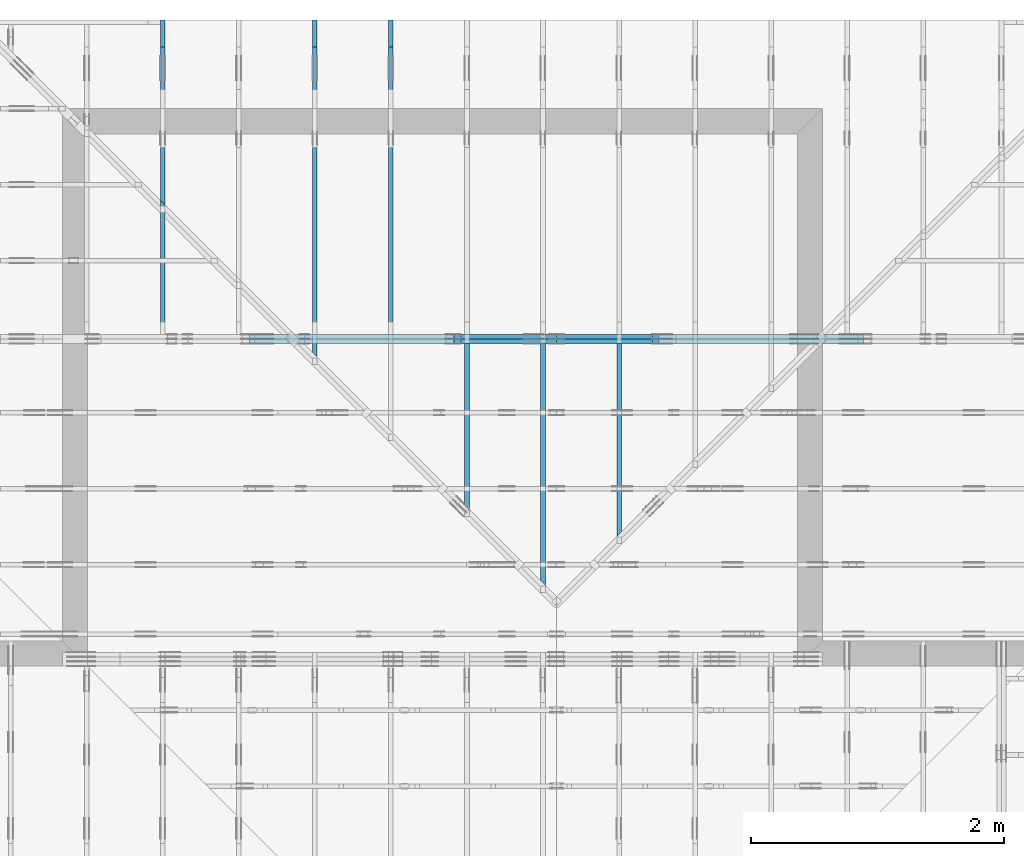
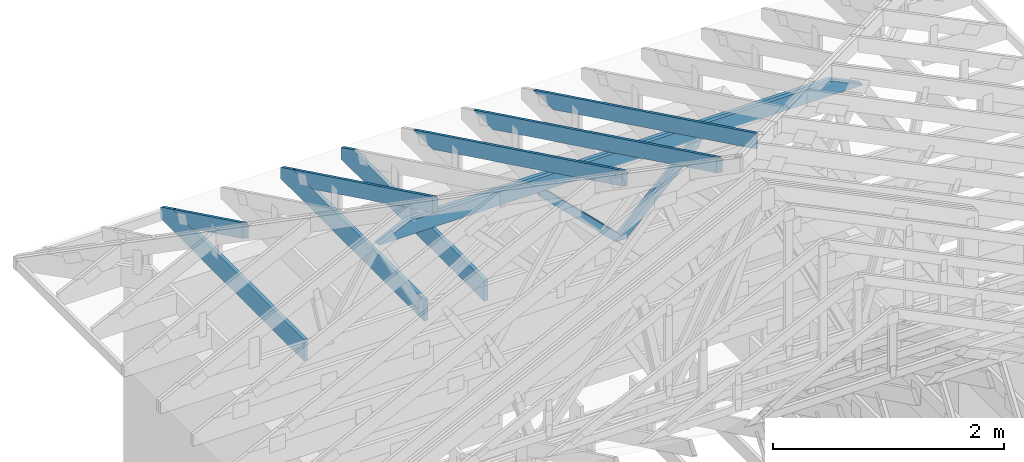
# One storey, part 27 of 159: 14 members, 7 elements without a shape of their own.
"""IFC2X3 building model written with IfcOpenShell, lengths in millimetres."""

import ifcopenshell
import ifcopenshell.guid

model = None  # the IFC model being written
_history = None  # IfcOwnerHistory: only IFC2X3 demands one
_inside = {}  # id of a spatial element -> (the spatial element, [elements in it])
_under = {}  # id of a project, library or spatial element -> (it, [spatial elements below it])
_declared = {}  # id of a project -> (the project, [libraries it declares])
_typed = {}  # id of a type object -> (the type object, [elements of that type])
_made_of = {}  # id of a material, layer set ... -> (it, [elements and type objects made of it])


def new_model(schema):
    """Start an empty IFC model of exactly this schema.

    Asked for "IFC4X3", IfcOpenShell would pick the latest addendum, in which some entities
    have other attributes; the version numbers below select the first issue.
    IFC2X3 requires an IfcOwnerHistory on every rooted entity: one is made here for all.
    """
    global model, _history
    if schema == "IFC4X3":
        model = ifcopenshell.file(schema_version=(4, 3, 0, 0))
    else:
        model = ifcopenshell.file(schema=schema)
    _inside.clear()
    _under.clear()
    _declared.clear()
    _typed.clear()
    _made_of.clear()
    _history = None
    if model.schema == "IFC2X3":
        org = make("IfcOrganization", Name="unknown")
        user = make(
            "IfcPersonAndOrganization",
            ThePerson=make("IfcPerson", FamilyName="unknown"),
            TheOrganization=org,
        )
        app = make(
            "IfcApplication",
            ApplicationDeveloper=org,
            Version="unknown",
            ApplicationFullName="unknown",
            ApplicationIdentifier="unknown",
        )
        _history = make(
            "IfcOwnerHistory",
            OwningUser=user,
            OwningApplication=app,
            ChangeAction="ADDED",
            CreationDate=0,
        )
    return model


def make(cls, **values):
    """One entity of the class cls with the attributes given. An attribute that is None is left unset."""
    return model.create_entity(
        cls, **{name: value for name, value in values.items() if value is not None}
    )


def rooted(cls, **values):
    """An entity with a GlobalId (a new one), such as an element, a storey or a relation."""
    return make(cls, GlobalId=ifcopenshell.guid.new(), OwnerHistory=_history, **values)


def si_unit(unit_type, name, prefix=None):
    """IfcSIUnit, for example si_unit("LENGTHUNIT", "METRE", prefix="MILLI")."""
    return make("IfcSIUnit", UnitType=unit_type, Prefix=prefix, Name=name)


def assignment(units):
    """IfcUnitAssignment: the units of a project."""
    return None if units is None else make("IfcUnitAssignment", Units=units)


def point(xyz):
    """IfcCartesianPoint."""
    return None if xyz is None else make("IfcCartesianPoint", Coordinates=xyz)


def direction(xyz):
    """IfcDirection."""
    return None if xyz is None else make("IfcDirection", DirectionRatios=xyz)


def frame(location, z_axis=None, x_axis=None):
    """IfcAxis2Placement3D, a coordinate frame: its origin and axes. An axis left out is left unset."""
    return make(
        "IfcAxis2Placement3D",
        Location=point(location),
        Axis=direction(z_axis),
        RefDirection=direction(x_axis),
    )


def frame_2d(location, x_axis=None):
    """IfcAxis2Placement2D, a coordinate frame in the plane: its origin and x axis."""
    return make(
        "IfcAxis2Placement2D", Location=point(location), RefDirection=direction(x_axis)
    )


def origin():
    """The frame at (0, 0, 0) with its axes left unset."""
    return frame((0.0, 0.0, 0.0))


def origin_with_axes():
    """The frame at (0, 0, 0) with the z axis (0, 0, 1) and the x axis (1, 0, 0) written out."""
    return frame((0.0, 0.0, 0.0), z_axis=(0.0, 0.0, 1.0), x_axis=(1.0, 0.0, 0.0))


def origin_2d():
    """The frame at (0, 0) in the plane with its x axis left unset."""
    return frame_2d((0.0, 0.0))


def place(relative_to, where):
    """IfcLocalPlacement: puts the frame where relative to a parent placement (None: the world)."""
    return make(
        "IfcLocalPlacement", PlacementRelTo=relative_to, RelativePlacement=where
    )


def context(
    kind, dimensions, precision=None, world=None, true_north=None, identifier=None
):
    """IfcGeometricRepresentationContext, for example the 3D "Model" context."""
    return make(
        "IfcGeometricRepresentationContext",
        ContextIdentifier=identifier,
        ContextType=kind,
        CoordinateSpaceDimension=dimensions,
        Precision=precision,
        WorldCoordinateSystem=world,
        TrueNorth=true_north,
    )


def project(units=None, contexts=None):
    """IfcProject with its units and contexts."""
    return rooted(
        "IfcProject",
        Name="project",
        RepresentationContexts=contexts,
        UnitsInContext=assignment(units),
    )


def spatial(cls, under=None, at=None, **own):
    """A site, building, storey or space (cls), placed at a placement, below another one or the project."""
    s = rooted(cls, ObjectPlacement=at, **own)
    if under is not None:
        _under.setdefault(under.id(), (under, []))[1].append(s)
    return s


def faces_of(points, faces, orient=None, outer=None):
    """IfcFace entities. A face is a list of loops; a loop is a list of indices into points, from 0.

    orient and outer hold one flag for each loop. By default every Orientation is true, the
    first loop of a face is its IfcFaceOuterBound and the others are IfcFaceBound.
    """
    made = []
    for i, loops in enumerate(faces):
        bounds = []
        for j, loop in enumerate(loops):
            is_outer = j == 0 if outer is None else outer[i][j]
            bounds.append(
                make(
                    "IfcFaceOuterBound" if is_outer else "IfcFaceBound",
                    Bound=make("IfcPolyLoop", Polygon=[points[k] for k in loop]),
                    Orientation=True if orient is None else orient[i][j],
                )
            )
        made.append(make("IfcFace", Bounds=bounds))
    return made


def faceted_brep(points, faces, orient=None, outer=None, voids=None):
    """IfcFacetedBrep: a solid bounded by flat faces; with voids (closed shells), ...WithVoids."""
    shared = [point(p) for p in points]
    hull = make("IfcClosedShell", CfsFaces=faces_of(shared, faces, orient, outer))
    if voids is None:
        return make("IfcFacetedBrep", Outer=hull)
    return make(
        "IfcFacetedBrepWithVoids",
        Outer=hull,
        Voids=[
            make(cls, CfsFaces=faces_of(shared, fs, o, b)) for cls, fs, o, b in voids
        ],
    )


def shape(context_of_items, identifier, shape_type, items):
    """IfcShapeRepresentation: the items that make up one representation, for example the "Body"."""
    return make(
        "IfcShapeRepresentation",
        ContextOfItems=context_of_items,
        RepresentationIdentifier=identifier,
        RepresentationType=shape_type,
        Items=items,
    )


def made_of(thing, what):
    """Note that an element or type object is made of a material, layer set ...; save() writes the relation."""
    if what is not None:
        _made_of.setdefault(what.id(), (what, []))[1].append(thing)
    return thing


def element(
    cls,
    number,
    at=None,
    inside=None,
    cuts=None,
    type_object=None,
    material=None,
    context=None,
    identifier="Body",
    shape_type=None,
    held_by="IfcProductDefinitionShape",
    body=None,
    shapes=None,
    **own,
):
    """One element of the class cls, such as IfcWall. Its Tag is "e" and its number.

    at: its placement. inside: the storey or other place that contains it. cuts: it is an
    opening in that element (IfcRelVoidsElement). A single representation is given by context,
    identifier, shape_type and body (its items); several are given by shapes. held_by: the class
    of the entity that holds the representations. save() writes the other relations.
    """
    e = rooted(cls, Tag="e%d" % number, ObjectPlacement=at, **own)
    if body is not None:
        shapes = [shape(context, identifier, shape_type, body)]
    if shapes is not None:
        e.Representation = make(held_by, Representations=shapes)
    if inside is not None:
        _inside.setdefault(inside.id(), (inside, []))[1].append(e)
    if cuts is not None:
        rooted(
            "IfcRelVoidsElement", RelatingBuildingElement=cuts, RelatedOpeningElement=e
        )
    if type_object is not None:
        _typed.setdefault(type_object.id(), (type_object, []))[1].append(e)
    return made_of(e, material)


def aggregate(whole, parts):
    """IfcRelAggregates: a whole, such as a stair, and the parts it consists of."""
    return rooted("IfcRelAggregates", RelatingObject=whole, RelatedObjects=parts)


def save(model, path):
    """Write the relations noted so far, then the file.

    IfcRelAggregates (storeys below a building ...), IfcRelContainedInSpatialStructure (elements
    in a storey), IfcRelDefinesByType, IfcRelAssociatesMaterial and IfcRelDeclares: one each for
    every whole, place, type object, material and project.
    """
    for whole, parts in _under.values():
        aggregate(whole, parts)
    for where, things in _inside.values():
        rooted(
            "IfcRelContainedInSpatialStructure",
            RelatedElements=things,
            RelatingStructure=where,
        )
    for kind, things in _typed.values():
        rooted("IfcRelDefinesByType", RelatedObjects=things, RelatingType=kind)
    for what, things in _made_of.values():
        rooted("IfcRelAssociatesMaterial", RelatedObjects=things, RelatingMaterial=what)
    for by, libraries in _declared.values():
        rooted("IfcRelDeclares", RelatingContext=by, RelatedDefinitions=libraries)
    model.write(path)


model = new_model("IFC2X3")

# Units and contexts
model_context = context("Model", 3, precision=1e-05, world=origin())
plan_context = context("Plan", 2, precision=1e-05, world=origin_2d())
ifc_project = project(units=[si_unit("LENGTHUNIT", "METRE", prefix="MILLI"), si_unit("AREAUNIT", "SQUARE_METRE"), si_unit("VOLUMEUNIT", "CUBIC_METRE"), si_unit("SOLIDANGLEUNIT", "STERADIAN"), si_unit("PLANEANGLEUNIT", "RADIAN"), si_unit("MASSUNIT", "GRAM"), si_unit("TIMEUNIT", "SECOND"), si_unit("THERMODYNAMICTEMPERATUREUNIT", "DEGREE_CELSIUS"), si_unit("LUMINOUSINTENSITYUNIT", "LUMEN")], contexts=[model_context, plan_context])

# Site, building, storey
site_placement = place(None, origin_with_axes())
site = spatial("IfcSite", under=ifc_project, at=site_placement, CompositionType="ELEMENT")
building_placement = place(site_placement, origin_with_axes())
building = spatial("IfcBuilding", under=site, at=building_placement, Name="Plan 1", CompositionType="ELEMENT")
storey_placement = place(building_placement, origin_with_axes())
storey = spatial("IfcBuildingStorey", under=building, at=storey_placement, Name="Etasje 1", CompositionType="ELEMENT", Elevation=0.0)

# Assembly, members
assembly_1_placement = place(storey_placement, frame((19200.01266310149, 11417.999978540158, 0.0), z_axis=(1.2246063538223773e-16, 1.0, 6.123031769111886e-17), x_axis=(-1.0, 1.2246063538223773e-16, 0.0)))
assembly_1 = element("IfcElementAssembly", 1, at=assembly_1_placement, inside=storey, Name="V9 (1)", AssemblyPlace="FACTORY", PredefinedType="TRUSS")
member_1_placement = place(assembly_1_placement, frame((2178.554843353704, 1017.8870849609375, -36.0), z_axis=(0.0, 0.0, 1.0), x_axis=(1.0, 0.0, 0.0)))
member_1 = element("IfcMember", 2, at=member_1_placement, Name="V9-O9", context=model_context, shape_type="Brep", body=[
    faceted_brep([(4539.445156646296, 148.0, 36.0), (303.4449125056708, 148.0, 36.0), (8.828692079987377e-05, 0.0, 36.0), (4842.890469146296, 0.0, 36.0), (303.4449125056708, 148.0, 3.716005678895198e-14), (4539.445156646296, 148.0, 5.55903338165727e-13), (4842.890469146296, 0.0, 5.930634439382387e-13), (8.828692079987377e-05, 0.0, 1.0811672417093842e-20), (9.042051300951238e-15, 2.0931263843173112e-05, -1.262965800692964e-30), (1.0008349875310733e-14, 2.093126384119191e-05, 36.0), (303.4449685537547, 148.0000209312639, 36.0), (303.4449685537547, 148.0000209312639, 3.1546734369853885e-30), (4842.890313291995, 2.0931262972116932e-05, 5.447019283343147e-29), (4842.890313291995, 2.0931262974321223e-05, 36.0), (4.049083948919771e-31, 2.093126386391636e-05, 36.0), (0.0, 2.093126386171207e-05, 0.0), (4539.445344738444, 148.00002093126363, -2.524354896707238e-29), (4539.445344738444, 148.00002093126363, 36.0), (4842.890313291995, 2.0931263406964717e-05, 36.0), (4842.890313291995, 2.0931263406964717e-05, -2.524354896707238e-29), (303.44496855375473, 148.00002093126383, -1.5777218104420236e-30), (303.44496855375473, 148.00002093126383, 36.0), (4539.445344738444, 148.00002093126358, 36.0), (4539.445344738444, 148.00002093126358, -1.735493991486226e-29)], [[[0, 1, 2, 3]], [[4, 5, 6, 7]], [[8, 9, 10, 11]], [[12, 13, 14, 15]], [[16, 17, 18, 19]], [[20, 21, 22, 23]]]),
])
member_2_placement = place(assembly_1_placement, frame((2178.554843353704, 1017.8870849609375, -72.0), z_axis=(0.0, 0.0, 1.0), x_axis=(1.0, 0.0, 0.0)))
member_2 = element("IfcMember", 3, at=member_2_placement, Name="V9-O9", context=model_context, shape_type="Brep", body=[
    faceted_brep([(4539.445156646296, 148.0, 36.0), (303.4449125056708, 148.0, 36.0), (8.828692079987377e-05, 0.0, 36.0), (4842.890469146296, 0.0, 36.0), (303.4449125056708, 148.0, 3.716005678895198e-14), (4539.445156646296, 148.0, 5.55903338165727e-13), (4842.890469146296, 0.0, 5.930634439382387e-13), (8.828692079987377e-05, 0.0, 1.0811672417093842e-20), (9.042051300951238e-15, 2.0931263843173112e-05, -1.262965800692964e-30), (1.0008349875310733e-14, 2.093126384119191e-05, 36.0), (303.4449685537547, 148.0000209312639, 36.0), (303.4449685537547, 148.0000209312639, 3.1546734369853885e-30), (4842.890313291995, 2.0931262972116932e-05, 5.447019283343147e-29), (4842.890313291995, 2.0931262974321223e-05, 36.0), (4.049083948919771e-31, 2.093126386391636e-05, 36.0), (0.0, 2.093126386171207e-05, 0.0), (4539.445344738444, 148.00002093126363, -2.524354896707238e-29), (4539.445344738444, 148.00002093126363, 36.0), (4842.890313291995, 2.0931263406964717e-05, 36.0), (4842.890313291995, 2.0931263406964717e-05, -2.524354896707238e-29), (303.44496855375473, 148.00002093126383, -1.5777218104420236e-30), (303.44496855375473, 148.00002093126383, 36.0), (4539.445344738444, 148.00002093126358, 36.0), (4539.445344738444, 148.00002093126358, -1.735493991486226e-29)], [[[0, 1, 2, 3]], [[4, 5, 6, 7]], [[8, 9, 10, 11]], [[12, 13, 14, 15]], [[16, 17, 18, 19]], [[20, 21, 22, 23]]]),
])
member_3_placement = place(assembly_1_placement, frame((3767.2404251676453, 991.8808911295935, -36.0), z_axis=(0.0, 0.0, 1.0), x_axis=(0.7124977998296568, -0.7016743441496905, 0.0)))
member_3 = element("IfcMember", 4, at=member_3_placement, Name="V9-D48", context=model_context, shape_type="Brep", body=[
    faceted_brep([(1096.897817485401, 73.00009422195262, 36.0), (37.06310576516216, 73.00009422195262, 36.0), (0.0, 36.500033877383885, 36.0), (67.97925100722796, 6.436748344640364e-05, 36.0), (1095.7802541025576, 6.436748344640364e-05, 36.0), (1132.8433598677202, 36.500033877383885, 36.0), (37.06310576516216, 73.00009422195262, 4.538771481240836e-15), (1096.897817485401, 73.00009422195262, 1.3432680367865203e-13), (1132.8433598677202, 36.500033877383885, 1.3872871763795e-13), (1095.7802541025576, 6.436748344640364e-05, 1.341899461567091e-13), (67.97925100722796, 6.436748344640364e-05, 8.32478227115376e-15), (0.0, 36.500033877383885, 0.0), (2.2328853447106667e-05, 36.50008524434588, -1.9721522630525295e-31), (2.2328853447106667e-05, 36.50008524434588, 36.0), (37.06304153514566, 73.00008524434679, 36.0), (37.06304153514566, 73.00008524434679, -3.944304526105059e-31), (67.97930220710211, 8.524434629464395e-05, 3.1554436208840472e-30), (67.97930220710211, 8.524434629819666e-05, 36.0), (2.232885345598845e-05, 36.5000852443459, 36.0), (2.2328853454212094e-05, 36.5000852443459, -7.888609052210118e-31), (1095.7803406618136, 8.524434613599157e-05, 1.2324740414699222e-29), (1095.7803406618136, 8.524434613819586e-05, 36.0), (67.97930220710214, 8.524434632699363e-05, 36.0), (67.97930220710214, 8.524434632478933e-05, 7.645941879217326e-31), (1132.843359868106, 36.500085244346906, -1.2621774483536187e-29), (1132.843359868106, 36.500085244346906, 36.0), (1095.7803406618134, 8.524434633727651e-05, 36.0), (1095.7803406618134, 8.524434633727651e-05, -1.2621774483536187e-29), (1096.8978263273898, 73.00008524434685, 0.0), (1096.8978263273898, 73.00008524434685, 36.0), (1132.8433598681063, 36.50008524434702, 36.0), (1132.8433598681063, 36.50008524434702, 0.0), (37.06304153514566, 73.00008524434679, 0.0), (37.06304153514566, 73.00008524434679, 36.0), (1096.8978263273898, 73.00008524434672, 36.0), (1096.8978263273898, 73.00008524434672, -3.944304526105059e-30)], [[[0, 1, 2, 3, 4, 5]], [[6, 7, 8, 9, 10, 11]], [[12, 13, 14, 15]], [[16, 17, 18, 19]], [[20, 21, 22, 23]], [[24, 25, 26, 27]], [[28, 29, 30, 31]], [[32, 33, 34, 35]]]),
])
member_4_placement = place(assembly_1_placement, frame((3767.2404251676453, 991.8808911295935, -72.0), z_axis=(0.0, 0.0, 1.0), x_axis=(0.7124977998296568, -0.7016743441496905, 0.0)))
member_4 = element("IfcMember", 5, at=member_4_placement, Name="V9-D48", context=model_context, shape_type="Brep", body=[
    faceted_brep([(1096.897817485401, 73.00009422195262, 36.0), (37.06310576516216, 73.00009422195262, 36.0), (0.0, 36.500033877383885, 36.0), (67.97925100722796, 6.436748344640364e-05, 36.0), (1095.7802541025576, 6.436748344640364e-05, 36.0), (1132.8433598677202, 36.500033877383885, 36.0), (37.06310576516216, 73.00009422195262, 4.538771481240836e-15), (1096.897817485401, 73.00009422195262, 1.3432680367865203e-13), (1132.8433598677202, 36.500033877383885, 1.3872871763795e-13), (1095.7802541025576, 6.436748344640364e-05, 1.341899461567091e-13), (67.97925100722796, 6.436748344640364e-05, 8.32478227115376e-15), (0.0, 36.500033877383885, 0.0), (2.2328853447106667e-05, 36.50008524434588, -1.9721522630525295e-31), (2.2328853447106667e-05, 36.50008524434588, 36.0), (37.06304153514566, 73.00008524434679, 36.0), (37.06304153514566, 73.00008524434679, -3.944304526105059e-31), (67.97930220710211, 8.524434629464395e-05, 3.1554436208840472e-30), (67.97930220710211, 8.524434629819666e-05, 36.0), (2.232885345598845e-05, 36.5000852443459, 36.0), (2.2328853454212094e-05, 36.5000852443459, -7.888609052210118e-31), (1095.7803406618136, 8.524434613599157e-05, 1.2324740414699222e-29), (1095.7803406618136, 8.524434613819586e-05, 36.0), (67.97930220710214, 8.524434632699363e-05, 36.0), (67.97930220710214, 8.524434632478933e-05, 7.645941879217326e-31), (1132.843359868106, 36.500085244346906, -1.2621774483536187e-29), (1132.843359868106, 36.500085244346906, 36.0), (1095.7803406618134, 8.524434633727651e-05, 36.0), (1095.7803406618134, 8.524434633727651e-05, -1.2621774483536187e-29), (1096.8978263273898, 73.00008524434685, 0.0), (1096.8978263273898, 73.00008524434685, 36.0), (1132.8433598681063, 36.50008524434702, 36.0), (1132.8433598681063, 36.50008524434702, 0.0), (37.06304153514566, 73.00008524434679, 0.0), (37.06304153514566, 73.00008524434679, 36.0), (1096.8978263273898, 73.00008524434672, 36.0), (1096.8978263273898, 73.00008524434672, -3.944304526105059e-30)], [[[0, 1, 2, 3, 4, 5]], [[6, 7, 8, 9, 10, 11]], [[12, 13, 14, 15]], [[16, 17, 18, 19]], [[20, 21, 22, 23]], [[24, 25, 26, 27]], [[28, 29, 30, 31]], [[32, 33, 34, 35]]]),
])
member_5_placement = place(assembly_1_placement, frame((5381.5372641250315, 1043.8933153908583, -36.0), z_axis=(0.0, 0.0, 1.0), x_axis=(-0.7124977998296527, -0.7016743441496947, 0.0)))
member_5 = element("IfcMember", 6, at=member_5_placement, Name="V9-D47", context=model_context, shape_type="Brep", body=[
    faceted_brep([(1095.7802541025585, 73.00011912134369, 36.0), (29.67218157822026, 73.00011912134369, 36.0), (0.0, 36.50008524396662, 36.0), (37.06310576516262, 0.0, 36.0), (1096.897817485401, 0.0, 36.0), (1132.8433598677207, 36.50008524396662, 36.0), (29.67218157822026, 73.00011912134369, 3.633674209245983e-15), (1095.7802541025585, 73.00011912134369, 1.3418994615670923e-13), (1132.8433598677207, 36.50008524396662, 1.3872871763795005e-13), (1096.897817485401, 0.0, 1.3432680367865203e-13), (37.06310576516262, 0.0, 4.538771481240892e-15), (0.0, 36.50008524396662, 0.0), (2.2328089478662605e-05, 36.500033877758135, -5.9164567891575885e-31), (2.2328089478662605e-05, 36.500033877758135, 36.0), (29.672212933261115, 73.00003387775767, 36.0), (29.672212933261115, 73.00003387775767, -7.888609052210118e-31), (37.06304153438032, 3.3877757687150734e-05, 3.5996285031249067e-31), (37.06304153438032, 3.3877757687150734e-05, 36.0), (2.2328089471557178e-05, 36.50003387775815, 36.0), (2.2328089471557178e-05, 36.50003387775815, 3.937450419442699e-32), (1096.8978263266172, 3.387775750156331e-05, -1.6480747523726356e-29), (1096.8978263266172, 3.38777575037676e-05, 36.0), (37.06304153438032, 3.387775769844966e-05, 36.0), (37.06304153438032, 3.387775769624537e-05, -5.568672209336865e-31), (1132.843359867335, 36.50003387775678, -5.059145655227509e-30), (1132.843359867335, 36.50003387775678, 36.0), (1096.8978263266172, 3.387775734609022e-05, 36.0), (1096.8978263266172, 3.387775734609022e-05, -1.1054314564169578e-29), (1095.780340661043, 73.0000338777574, 1.8932661725304283e-29), (1095.780340661043, 73.0000338777574, 36.0), (1132.8433598673353, 36.50003387775689, 36.0), (1132.8433598673353, 36.50003387775689, 1.262177448353619e-29), (29.67221293326111, 73.00003387775769, 0.0), (29.67221293326111, 73.00003387775769, 36.0), (1095.7803406610428, 73.00003387775715, 36.0), (1095.7803406610428, 73.00003387775715, -5.5220263365470826e-30)], [[[0, 1, 2, 3, 4, 5]], [[6, 7, 8, 9, 10, 11]], [[12, 13, 14, 15]], [[16, 17, 18, 19]], [[20, 21, 22, 23]], [[24, 25, 26, 27]], [[28, 29, 30, 31]], [[32, 33, 34, 35]]]),
])
member_6_placement = place(assembly_1_placement, frame((5381.5372641250315, 1043.8933153908583, -72.0), z_axis=(0.0, 0.0, 1.0), x_axis=(-0.7124977998296527, -0.7016743441496947, 0.0)))
member_6 = element("IfcMember", 7, at=member_6_placement, Name="V9-D47", context=model_context, shape_type="Brep", body=[
    faceted_brep([(1095.7802541025585, 73.00011912134369, 36.0), (29.67218157822026, 73.00011912134369, 36.0), (0.0, 36.50008524396662, 36.0), (37.06310576516262, 0.0, 36.0), (1096.897817485401, 0.0, 36.0), (1132.8433598677207, 36.50008524396662, 36.0), (29.67218157822026, 73.00011912134369, 3.633674209245983e-15), (1095.7802541025585, 73.00011912134369, 1.3418994615670923e-13), (1132.8433598677207, 36.50008524396662, 1.3872871763795005e-13), (1096.897817485401, 0.0, 1.3432680367865203e-13), (37.06310576516262, 0.0, 4.538771481240892e-15), (0.0, 36.50008524396662, 0.0), (2.2328089478662605e-05, 36.500033877758135, -5.9164567891575885e-31), (2.2328089478662605e-05, 36.500033877758135, 36.0), (29.672212933261115, 73.00003387775767, 36.0), (29.672212933261115, 73.00003387775767, -7.888609052210118e-31), (37.06304153438032, 3.3877757687150734e-05, 3.5996285031249067e-31), (37.06304153438032, 3.3877757687150734e-05, 36.0), (2.2328089471557178e-05, 36.50003387775815, 36.0), (2.2328089471557178e-05, 36.50003387775815, 3.937450419442699e-32), (1096.8978263266172, 3.387775750156331e-05, -1.6480747523726356e-29), (1096.8978263266172, 3.38777575037676e-05, 36.0), (37.06304153438032, 3.387775769844966e-05, 36.0), (37.06304153438032, 3.387775769624537e-05, -5.568672209336865e-31), (1132.843359867335, 36.50003387775678, -5.059145655227509e-30), (1132.843359867335, 36.50003387775678, 36.0), (1096.8978263266172, 3.387775734609022e-05, 36.0), (1096.8978263266172, 3.387775734609022e-05, -1.1054314564169578e-29), (1095.780340661043, 73.0000338777574, 1.8932661725304283e-29), (1095.780340661043, 73.0000338777574, 36.0), (1132.8433598673353, 36.50003387775689, 36.0), (1132.8433598673353, 36.50003387775689, 1.262177448353619e-29), (29.67221293326111, 73.00003387775769, 0.0), (29.67221293326111, 73.00003387775769, 36.0), (1095.7803406610428, 73.00003387775715, 36.0), (1095.7803406610428, 73.00003387775715, -5.5220263365470826e-30)], [[[0, 1, 2, 3, 4, 5]], [[6, 7, 8, 9, 10, 11]], [[12, 13, 14, 15]], [[16, 17, 18, 19]], [[20, 21, 22, 23]], [[24, 25, 26, 27]], [[28, 29, 30, 31]], [[32, 33, 34, 35]]]),
])
aggregate(assembly_1, [member_1, member_2, member_3, member_4, member_5, member_6])

# Assembly, member
assembly_2_placement = place(storey_placement, frame((15075.022261404756, 13899.999978540158, 1.1021457184401395e-15), z_axis=(-1.0, 1.836909530733566e-16, 6.123031769111886e-17), x_axis=(-1.836909530733566e-16, -1.0, 0.0)))
assembly_2 = element("IfcElementAssembly", 8, at=assembly_2_placement, inside=storey, Name="S37 (66)", AssemblyPlace="FACTORY", PredefinedType="TRUSS")
member_7_placement = place(assembly_2_placement, frame((276.06020326652146, 89.97847034696025, -36.000000217579284), z_axis=(0.0, 0.0, 1.0), x_axis=(0.8987940462991669, 0.43837114678907757, 0.0)))
member_7 = element("IfcMember", 9, at=member_7_placement, Name="S37-O17", context=model_context, shape_type="Brep", body=[
    faceted_brep([(4297.867188344495, 147.9999948190857, 36.00000324776238), (4225.682764393419, 2.3761685952194966e-09, 36.00000021757933), (4185.629094450884, 3.235559233871754e-07, 2.2737367544323206e-13), (4257.813518401959, 147.99999514026604, 3.030183052032953e-06), (0.0, 147.99999999998036, 2.1757928436727525e-07), (0.0, 147.99999999998036, 36.00000021757929), (4297.8671875, 147.9999999999801, 36.00000021757929), (4257.81351852417, 147.9999999999801, 2.1757928436727525e-07), (4.1080401842918945e-05, 148.00000000212168, 2.1757928436728028e-07), (4257.813517642902, 148.00000000212168, 2.1757980578182396e-07), (4185.629092288898, 5.684341886080802e-14, 2.1757979694207337e-07), (303.44510943977707, 5.684341886080802e-14, 2.1757932152735617e-07), (303.4449931897631, 1.1566498869797215e-09, 2.1757928436727525e-07), (303.4449931897631, 1.1566498869797215e-09, 36.000000217579284), (2.1476631893335707e-05, 148.00000154209687, 36.000000217579284), (2.1476631893335707e-05, 148.00000154209687, 2.1757928436727525e-07), (4225.682763512138, 2.362666097071262e-09, 36.000000217579284), (303.4450125050573, 2.3633865766619247e-09, 36.000000217579284), (303.4450125050573, 2.363384372370488e-09, 2.1757928436727525e-07), (4185.629094536308, 2.3626712502764533e-09, 2.1757928436727525e-07), (4297.867189747425, 148.00000000237588, 36.000000217579284), (0.00014720592025696533, 148.00000000237588, 36.000000217579284), (303.44497142467026, 1.1569909474928863e-09, 36.000000217579284), (4225.68276439342, 1.1569909474928863e-09, 36.000000217579284)], [[[0, 1, 2, 3]], [[4, 5, 6, 7]], [[8, 9, 10, 11]], [[12, 13, 14, 15]], [[16, 17, 18, 19]], [[20, 21, 22, 23]]]),
])
aggregate(assembly_2, [member_7])

assembly_3_placement = place(storey_placement, frame((14475.022261404756, 13899.999978540158, 1.1021457184401395e-15), z_axis=(-1.0, 1.836909530733566e-16, 6.123031769111886e-17), x_axis=(-1.836909530733566e-16, -1.0, 0.0)))
assembly_3 = element("IfcElementAssembly", 10, at=assembly_3_placement, inside=storey, Name="S36 (68)", AssemblyPlace="FACTORY", PredefinedType="TRUSS")
member_8_placement = place(assembly_3_placement, frame((276.06010265352234, 89.97842091887203, -36.00000021758233), z_axis=(0.0, 0.0, 1.0), x_axis=(0.8987940462991671, 0.4383711467890776, 0.0)))
member_8 = element("IfcMember", 11, at=member_8_placement, Name="S36-O13", context=model_context, shape_type="Brep", body=[
    faceted_brep([(4727.826169858939, 148.00000083081466, 2.2533308765559923e-06), (4687.7725028616005, 147.9999951378894, 35.99999718737445), (4615.5880789105, 3.211918055967544e-07, 36.00000021758342), (4655.641748853033, -1.1368683772161603e-13, 1.3642420526593924e-12), (4.1080393884840305e-05, 148.00000032047132, 2.1758233259561163e-07), (4.1080393884840305e-05, 148.00000032047132, 36.00000021758233), (4687.772502017895, 148.00000032047103, 36.00000021758233), (4727.826170993725, 148.00000032047103, 2.1758233259561163e-07), (303.44510528797554, 3.2099225677484355e-07, 2.1758233259561166e-07), (303.44510528797554, 3.2099225677484355e-07, 36.00000021758233), (0.00013357484424858512, 148.0000018619325, 36.00000021758233), (0.00013357484424858512, 148.0000018619325, 2.1758233259561166e-07), (4655.641748767606, 3.2119315540106607e-07, 2.1758233259561166e-07), (4615.588079791775, 3.2119316496285414e-07, 36.00000021758233), (303.44497142385507, 3.211939570645315e-07, 36.00000021758233), (303.44497142385507, 3.2119395486024007e-07, 2.1758233259561166e-07), (4687.7725042645025, 148.00000032119237, 36.00000021758233), (0.00018828549838190156, 148.00000032119237, 36.00000021758233), (303.4450125042486, 3.209923704616813e-07, 36.00000021758233), (4615.5880789104995, 3.209923704616813e-07, 36.00000021758233), (0.0, 148.0000003203246, 2.1758233259561166e-07), (4727.826171875002, 148.0000003203246, 2.1758291156820865e-07), (4655.641746520997, 3.2047250897448976e-07, 2.1758290272845806e-07), (303.4453125000006, 3.2047250897448976e-07, 2.1758236975571743e-07)], [[[0, 1, 2, 3]], [[4, 5, 6, 7]], [[8, 9, 10, 11]], [[12, 13, 14, 15]], [[16, 17, 18, 19]], [[20, 21, 22, 23]]]),
])
aggregate(assembly_3, [member_8])

# Assembly, members
assembly_4_placement = place(storey_placement, frame((12675.022261404758, 13899.999978540158, 1.1021457184401395e-15), z_axis=(-1.0, 1.836909530733566e-16, 6.123031769111886e-17), x_axis=(-1.836909530733566e-16, -1.0, 0.0)))
assembly_4 = element("IfcElementAssembly", 12, at=assembly_4_placement, inside=storey, Name="S33 (69)", AssemblyPlace="FACTORY", PredefinedType="TRUSS")
member_9_placement = place(assembly_4_placement, frame((276.0601246734584, 89.9784316596411, -36.00000021758836), z_axis=(0.0, 0.0, 1.0), x_axis=(0.8987940462991671, 0.43837114678907757, 0.0)))
member_9 = element("IfcMember", 13, at=member_9_placement, Name="S33-O42", context=model_context, shape_type="Brep", body=[
    faceted_brep([(2724.6694874327823, 148.00000083082773, 2.2533290575665887e-06), (2684.615820435449, 147.99999513789294, 35.99999718737786), (2612.4313964843755, 3.2118293802341213e-07, 36.00000021758865), (2652.4850664269034, -1.1368683772161603e-13, 0.0), (9.693553448641978e-05, 148.00000032048894, 2.1758835089258355e-07), (9.693553448641978e-05, 148.00000032048894, 36.00000021758835), (2684.615819591785, 148.00000032048877, 36.00000021758835), (2724.669488567615, 148.00000032048877, 2.1758835089258355e-07), (303.4450807881445, 3.20156942734684e-07, 2.1758835089258355e-07), (303.4450807881445, 3.20156942734684e-07, 36.00000021758835), (0.00010907501319223911, 148.0000018610972, 36.00000021758835), (0.00010907501319223911, 148.0000018610972, 2.1758835089258355e-07), (2652.4850663414923, 3.212003638057803e-07, 2.1758835089258355e-07), (2612.4313973656617, 3.212003733675684e-07, 36.00000021758835), (303.4450272789914, 3.2120079750747536e-07, 36.00000021758835), (303.4450272789914, 3.212007953031839e-07, 2.1758835089258355e-07), (2684.615821838379, 148.00000032118328, 36.00000021758835), (0.0, 148.00000032118328, 36.00000021758835), (303.44506835937494, 3.2015708484323113e-07, 36.00000021758835), (2612.4313964843755, 3.2015708484323113e-07, 36.00000021758835), (5.5855137304661184e-05, 148.00000032112175, 2.1758835089259038e-07), (2724.669489448888, 148.00000032112175, 2.1758868455734042e-07), (2652.4850640948835, 3.2047933018475305e-07, 2.1758867571758984e-07), (303.44512421451253, 3.2047933018475305e-07, 2.1758838805266627e-07)], [[[0, 1, 2, 3]], [[4, 5, 6, 7]], [[8, 9, 10, 11]], [[12, 13, 14, 15]], [[16, 17, 18, 19]], [[20, 21, 22, 23]]]),
])
member_10_placement = place(assembly_4_placement, frame((2482.0, 223.00000000093104, -36.0), z_axis=(0.0, 0.0, 1.0), x_axis=(-1.0, 1.2246063538223773e-16, 0.0)))
member_10 = element("IfcMember", 14, at=member_10_placement, Name="S33-U12", context=model_context, shape_type="Brep", body=[
    faceted_brep([(2482.0, 223.00000000093135, 36.0), (0.0, 223.00000000093135, 36.0), (0.0, 9.310383575211745e-10, 36.0), (2270.8187103271484, 9.310383575211745e-10, 36.0), (2482.000000000002, 103.00000000093135, 36.0), (0.0, 223.00000000093135, 0.0), (2482.0, 223.00000000093135, 3.0394729701871404e-13), (2482.000000000002, 103.00000000093135, 3.0394729701871424e-13), (2270.8187103271484, 9.310383575211745e-10, 2.7808590210453623e-13), (0.0, 9.310383575211745e-10, 0.0), (1.8189894035459704e-12, 9.310383575211745e-10, -6.97286115848029e-42), (1.8211936949828507e-12, 9.310383575211745e-10, 36.0), (1.8485024166730897e-12, 223.00000000093104, 36.0), (1.8462981252362094e-12, 223.00000000093104, -1.672121704838656e-30), (2270.8187043163925, 8.33939117296296e-13, -5.106235708711034e-29), (2270.8187043163925, 8.361434087331763e-13, 36.0), (1.8189894035458573e-12, 9.310405618126114e-10, 36.0), (1.8189894035458565e-12, 9.310383575211745e-10, 0.0), (2482.000000000001, 103.00000000074351, -9.396085556655556e-29), (2482.000000000001, 103.00000000074351, 36.0), (2270.818704316392, 1.2505552149377763e-12, 36.0), (2270.818704316392, 1.2505552149377763e-12, -8.206310969932178e-29), (2482.000000000003, 223.00000000093135, 2.0194839173657902e-28), (2482.000000000003, 223.00000000093135, 36.0), (2482.000000000003, 103.00000000074218, 36.0), (2482.000000000003, 103.00000000074218, 1.0097419586828951e-28), (1.818989403545857e-12, 223.00000000093104, 0.0), (1.818989403545857e-12, 223.00000000093104, 36.0), (2482.0, 223.00000000093144, 36.0), (2482.0, 223.00000000093144, 4.733165431326071e-30)], [[[0, 1, 2, 3, 4]], [[5, 6, 7, 8, 9]], [[10, 11, 12, 13]], [[14, 15, 16, 17]], [[18, 19, 20, 21]], [[22, 23, 24, 25]], [[26, 27, 28, 29]]]),
])
aggregate(assembly_4, [member_9, member_10])

assembly_5_placement = place(storey_placement, frame((11475.022261404758, 13899.999978540158, 1.1021457184401395e-15), z_axis=(-1.0, 1.836909530733566e-16, 6.123031769111886e-17), x_axis=(-1.836909530733566e-16, -1.0, 0.0)))
assembly_5 = element("IfcElementAssembly", 15, at=assembly_5_placement, inside=storey, Name="S31 (70)", AssemblyPlace="FACTORY", PredefinedType="TRUSS")
member_11_placement = place(assembly_5_placement, frame((276.06018210243076, 89.97845966776637, -36.00000021758075), z_axis=(0.0, 0.0, 1.0), x_axis=(0.8987940462991671, 0.4383711467890776, 0.0)))
member_11 = element("IfcMember", 16, at=member_11_placement, Name="S31-O64", context=model_context, shape_type="Brep", body=[
    faceted_brep([(1389.869316534364, 148.00000083082165, 2.2533431547344662e-06), (1349.8156495370245, 147.99999513789004, 35.99999718738434), (1277.6312255859382, 3.2118623494170606e-07, 36.00000021758092), (1317.684895528473, -5.684341886080802e-14, 1.1368683772161603e-13), (9.693631170648587e-05, 148.00000032208501, 2.1758074097988356e-07), (9.693631170648587e-05, 148.00000032208513, 36.00000021758074), (1349.8156486941243, 148.00000032208536, 36.00000021758074), (1389.8693176699544, 148.00000032208524, 2.1758074097988356e-07), (303.4450168933721, 3.218252260239751e-07, 2.1758074097988356e-07), (303.4450168933721, 3.218252260239751e-07, 36.00000021758074), (4.518024086053174e-05, 148.0000018627655, 36.00000021758074), (4.518024086053174e-05, 148.00000186276546, 2.1758074097988356e-07), (1317.6848954430325, 3.2115969431034874e-07, 2.1758074097988358e-07), (1277.6312264672024, 3.211597038721368e-07, 36.00000021758074), (303.44502727896986, 3.211598828213282e-07, 36.00000021758074), (303.44502727896986, 3.2115988061703675e-07, 2.1758074097988358e-07), (1349.8156509399414, 148.00000032118635, 36.00000021758074), (0.0, 148.00000032118635, 36.00000021758074), (303.445007324219, 3.218252970782487e-07, 36.00000021758074), (1277.631225585938, 3.218252970782487e-07, 36.00000021758074), (5.5855932089343696e-05, 148.00000032115707, 2.175807409798904e-07), (1389.8693185512448, 148.00000032115707, 2.175809111841634e-07), (1317.6848931972409, 3.221126689822995e-07, 2.1758090234441282e-07), (303.44500214499453, 3.221126689822995e-07, 2.1758077813995132e-07)], [[[0, 1, 2, 3]], [[4, 5, 6, 7]], [[8, 9, 10, 11]], [[12, 13, 14, 15]], [[16, 17, 18, 19]], [[20, 21, 22, 23]]]),
])
member_12_placement = place(assembly_5_placement, frame((2482.0, 223.00000000093104, -36.0), z_axis=(0.0, 0.0, 1.0), x_axis=(-1.0, 1.2246063538223773e-16, 0.0)))
member_12 = element("IfcMember", 17, at=member_12_placement, Name="S31-U12", context=model_context, shape_type="Brep", body=[
    faceted_brep([(2482.0, 223.00000000093135, 36.0), (0.0, 223.00000000093135, 36.0), (0.0, 9.310383575211745e-10, 36.0), (2270.8187103271484, 9.310383575211745e-10, 36.0), (2482.000000000002, 103.00000000093135, 36.0), (0.0, 223.00000000093135, 0.0), (2482.0, 223.00000000093135, 3.0394729701871404e-13), (2482.000000000002, 103.00000000093135, 3.0394729701871424e-13), (2270.8187103271484, 9.310383575211745e-10, 2.7808590210453623e-13), (0.0, 9.310383575211745e-10, 0.0), (1.1401554882727804e-25, 9.310383575211745e-10, -6.981208276421509e-42), (2.2042914369942947e-15, 9.310383575211745e-10, 36.0), (2.9513013127233304e-14, 223.00000000093104, 36.0), (2.730872169035303e-14, 223.00000000093104, -1.6721217048386645e-30), (2270.8187043163925, 8.339391172955722e-13, -5.106235708706442e-29), (2270.8187043163925, 8.361434087324525e-13, 36.0), (9.029525915557911e-28, 9.310405618126114e-10, 36.0), (0.0, 9.310383575211745e-10, 0.0), (2482.000000000001, 103.00000000074351, -9.396085556655556e-29), (2482.000000000001, 103.00000000074351, 36.0), (2270.818704316392, 1.2505552149377763e-12, 36.0), (2270.818704316392, 1.2505552149377763e-12, -8.206310969932178e-29), (2482.000000000003, 223.00000000093135, 2.0194839173657902e-28), (2482.000000000003, 223.00000000093135, 36.0), (2482.000000000003, 103.00000000074218, 36.0), (2482.000000000003, 103.00000000074218, 1.0097419586828951e-28), (0.0, 223.00000000093104, 0.0), (0.0, 223.00000000093104, 36.0), (2482.0, 223.00000000093144, 36.0), (2482.0, 223.00000000093144, 4.733165431326071e-30)], [[[0, 1, 2, 3, 4]], [[5, 6, 7, 8, 9]], [[10, 11, 12, 13]], [[14, 15, 16, 17]], [[18, 19, 20, 21]], [[22, 23, 24, 25]], [[26, 27, 28, 29]]]),
])
aggregate(assembly_5, [member_11, member_12])

# Assembly, member
assembly_6_placement = place(storey_placement, frame((13275.022261404756, 13899.999978540158, 1.1021457184401395e-15), z_axis=(-1.0, 1.836909530733566e-16, 6.123031769111886e-17), x_axis=(-1.836909530733566e-16, -1.0, 0.0)))
assembly_6 = element("IfcElementAssembly", 18, at=assembly_6_placement, inside=storey, Name="S34 (71)", AssemblyPlace="FACTORY", PredefinedType="TRUSS")
member_13_placement = place(assembly_6_placement, frame((2482.0, 223.00000000093104, -36.0), z_axis=(0.0, 0.0, 1.0), x_axis=(-1.0, 1.2246063538223773e-16, 0.0)))
member_13 = element("IfcMember", 19, at=member_13_placement, Name="S34-U12", context=model_context, shape_type="Brep", body=[
    faceted_brep([(2482.0, 223.00000000093135, 36.0), (0.0, 223.00000000093135, 36.0), (0.0, 9.310383575211745e-10, 36.0), (2270.8187103271484, 9.310383575211745e-10, 36.0), (2482.000000000002, 103.00000000093135, 36.0), (0.0, 223.00000000093135, 0.0), (2482.0, 223.00000000093135, 3.0394729701871404e-13), (2482.000000000002, 103.00000000093135, 3.0394729701871424e-13), (2270.8187103271484, 9.310383575211745e-10, 2.7808590210453623e-13), (0.0, 9.310383575211745e-10, 0.0), (1.8189894035459704e-12, 9.310383575211745e-10, -6.97286115848029e-42), (1.8211936949828507e-12, 9.310383575211745e-10, 36.0), (1.8485024166730897e-12, 223.00000000093104, 36.0), (1.8462981252362094e-12, 223.00000000093104, -1.672121704838656e-30), (2270.8187043163925, 8.33939117296296e-13, -5.106235708711034e-29), (2270.8187043163925, 8.361434087331763e-13, 36.0), (1.8189894035458573e-12, 9.310405618126114e-10, 36.0), (1.8189894035458565e-12, 9.310383575211745e-10, 0.0), (2482.000000000001, 103.00000000074351, -9.396085556655556e-29), (2482.000000000001, 103.00000000074351, 36.0), (2270.818704316392, 1.2505552149377763e-12, 36.0), (2270.818704316392, 1.2505552149377763e-12, -8.206310969932178e-29), (2482.000000000003, 223.00000000093135, 2.0194839173657902e-28), (2482.000000000003, 223.00000000093135, 36.0), (2482.000000000003, 103.00000000074218, 36.0), (2482.000000000003, 103.00000000074218, 1.0097419586828951e-28), (1.818989403545857e-12, 223.00000000093104, 0.0), (1.818989403545857e-12, 223.00000000093104, 36.0), (2482.0, 223.00000000093144, 36.0), (2482.0, 223.00000000093144, 4.733165431326071e-30)], [[[0, 1, 2, 3, 4]], [[5, 6, 7, 8, 9]], [[10, 11, 12, 13]], [[14, 15, 16, 17]], [[18, 19, 20, 21]], [[22, 23, 24, 25]], [[26, 27, 28, 29]]]),
])
aggregate(assembly_6, [member_13])

assembly_7_placement = place(storey_placement, frame((13875.022261404758, 13899.999978540158, 1.1021457184401395e-15), z_axis=(-1.0, 1.836909530733566e-16, 6.123031769111886e-17), x_axis=(-1.836909530733566e-16, -1.0, 0.0)))
assembly_7 = element("IfcElementAssembly", 20, at=assembly_7_placement, inside=storey, Name="S35 (73)", AssemblyPlace="FACTORY", PredefinedType="TRUSS")
member_14_placement = place(assembly_7_placement, frame((276.06013736182206, 89.97843784713469, -36.00000021760372), z_axis=(0.0, 0.0, 1.0), x_axis=(0.8987940462991669, 0.4383711467890776, 0.0)))
member_14 = element("IfcMember", 21, at=member_14_placement, Name="S35-O23", context=model_context, shape_type="Brep", body=[
    faceted_brep([(4059.791801885869, 148.00000083083967, 2.2533022274728864e-06), (4019.73813488855, 147.9999951378976, 35.99999718736649), (3947.5537109375, 3.2117577575263567e-07, 36.000000217603656), (3987.6073808800147, -1.1368683772161603e-13, 2.2737367544323206e-13), (9.69355203892519e-05, 148.0000003204555, 2.1760371282653068e-07), (9.69355203892519e-05, 148.0000003204555, 36.00000021760371), (4019.7381340448956, 148.00000032045526, 36.00000021760371), (4059.7918030207256, 148.00000032045526, 2.1760371282653068e-07), (303.4450666715, 3.210868015912638e-07, 2.1760371282653068e-07), (303.4450666715, 3.210868015912638e-07, 36.00000021760371), (9.495836887651876e-05, 148.00000186202732, 36.00000021760371), (9.495836887651876e-05, 148.00000186202732, 2.1760371282653068e-07), (3987.6073807946077, 3.2117663488096354e-07, 2.1760371282653068e-07), (3947.5537118187776, 3.211766444427516e-07, 36.00000021760371), (303.4450272789822, 3.2117731383254896e-07, 36.00000021760371), (303.4450272789822, 3.2117731162825753e-07, 2.1760371282653068e-07), (4019.738136291504, 148.00000032117646, 36.00000021760371), (0.0, 148.00000032117646, 36.00000021760371), (303.4450683593747, 3.2108695791066566e-07, 36.00000021760371), (3947.5537109375, 3.2108695791066566e-07, 36.00000021760371), (5.585512803918391e-05, 148.0000003204188, 2.176037128265375e-07), (4059.7918039020033, 148.0000003204188, 2.176042099912145e-07), (3987.6073785479994, 3.2045568332250696e-07, 2.1760420115146393e-07), (303.44512421450275, 3.2045568332250696e-07, 2.176037499866134e-07)], [[[0, 1, 2, 3]], [[4, 5, 6, 7]], [[8, 9, 10, 11]], [[12, 13, 14, 15]], [[16, 17, 18, 19]], [[20, 21, 22, 23]]]),
])
aggregate(assembly_7, [member_14])

save(model, "model.ifc")
